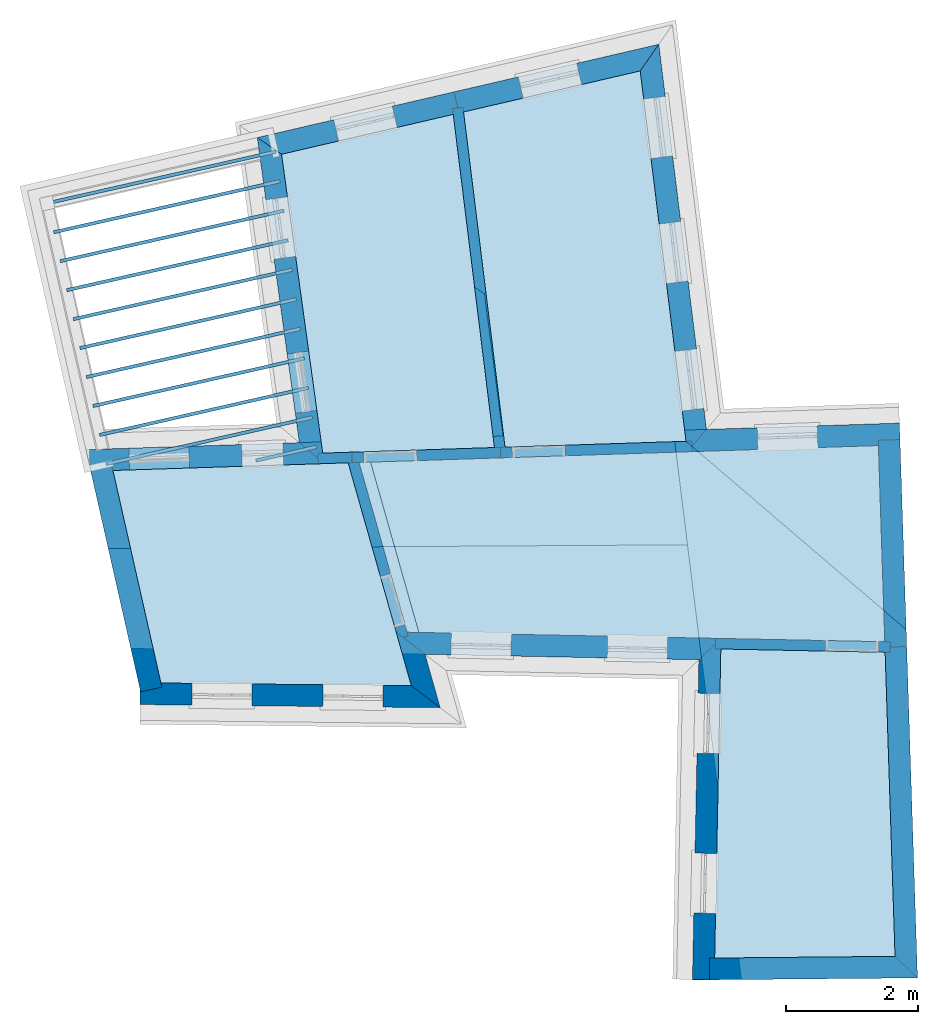
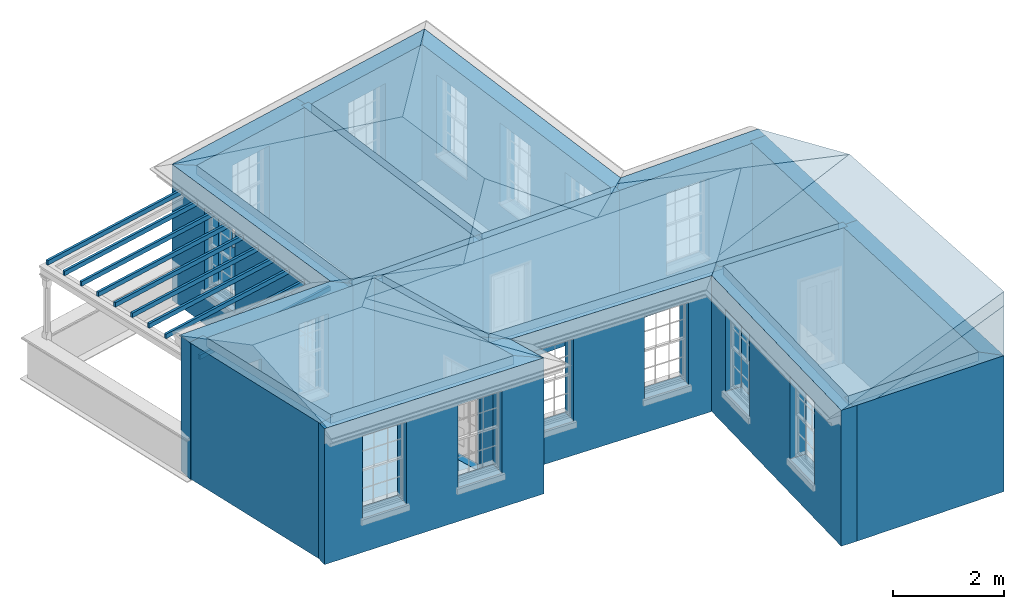
# One storey, part 1 of 11: 20 slabs, 20 walls, 5 roofs, 20 openings.
"""IFC2X3 building model written with IfcOpenShell, lengths in metres."""

import ifcopenshell
import ifcopenshell.guid

model = None  # the IFC model being written
_history = None  # IfcOwnerHistory: only IFC2X3 demands one
_inside = {}  # id of a spatial element -> (the spatial element, [elements in it])
_under = {}  # id of a project, library or spatial element -> (it, [spatial elements below it])
_declared = {}  # id of a project -> (the project, [libraries it declares])
_typed = {}  # id of a type object -> (the type object, [elements of that type])
_made_of = {}  # id of a material, layer set ... -> (it, [elements and type objects made of it])


def new_model(schema):
    """Start an empty IFC model of exactly this schema.

    Asked for "IFC4X3", IfcOpenShell would pick the latest addendum, in which some entities
    have other attributes; the version numbers below select the first issue.
    IFC2X3 requires an IfcOwnerHistory on every rooted entity: one is made here for all.
    """
    global model, _history
    if schema == "IFC4X3":
        model = ifcopenshell.file(schema_version=(4, 3, 0, 0))
    else:
        model = ifcopenshell.file(schema=schema)
    _inside.clear()
    _under.clear()
    _declared.clear()
    _typed.clear()
    _made_of.clear()
    _history = None
    if model.schema == "IFC2X3":
        org = make("IfcOrganization", Name="unknown")
        user = make(
            "IfcPersonAndOrganization",
            ThePerson=make("IfcPerson", FamilyName="unknown"),
            TheOrganization=org,
        )
        app = make(
            "IfcApplication",
            ApplicationDeveloper=org,
            Version="unknown",
            ApplicationFullName="unknown",
            ApplicationIdentifier="unknown",
        )
        _history = make(
            "IfcOwnerHistory",
            OwningUser=user,
            OwningApplication=app,
            ChangeAction="ADDED",
            CreationDate=0,
        )
    return model


def make(cls, **values):
    """One entity of the class cls with the attributes given. An attribute that is None is left unset."""
    return model.create_entity(
        cls, **{name: value for name, value in values.items() if value is not None}
    )


def rooted(cls, **values):
    """An entity with a GlobalId (a new one), such as an element, a storey or a relation."""
    return make(cls, GlobalId=ifcopenshell.guid.new(), OwnerHistory=_history, **values)


def si_unit(unit_type, name, prefix=None):
    """IfcSIUnit, for example si_unit("LENGTHUNIT", "METRE", prefix="MILLI")."""
    return make("IfcSIUnit", UnitType=unit_type, Prefix=prefix, Name=name)


def assignment(units):
    """IfcUnitAssignment: the units of a project."""
    return None if units is None else make("IfcUnitAssignment", Units=units)


def point(xyz):
    """IfcCartesianPoint."""
    return None if xyz is None else make("IfcCartesianPoint", Coordinates=xyz)


def direction(xyz):
    """IfcDirection."""
    return None if xyz is None else make("IfcDirection", DirectionRatios=xyz)


def frame(location, z_axis=None, x_axis=None):
    """IfcAxis2Placement3D, a coordinate frame: its origin and axes. An axis left out is left unset."""
    return make(
        "IfcAxis2Placement3D",
        Location=point(location),
        Axis=direction(z_axis),
        RefDirection=direction(x_axis),
    )


def origin():
    """The frame at (0, 0, 0) with its axes left unset."""
    return frame((0.0, 0.0, 0.0))


def place(relative_to, where):
    """IfcLocalPlacement: puts the frame where relative to a parent placement (None: the world)."""
    return make(
        "IfcLocalPlacement", PlacementRelTo=relative_to, RelativePlacement=where
    )


def context(
    kind, dimensions, precision=None, world=None, true_north=None, identifier=None
):
    """IfcGeometricRepresentationContext, for example the 3D "Model" context."""
    return make(
        "IfcGeometricRepresentationContext",
        ContextIdentifier=identifier,
        ContextType=kind,
        CoordinateSpaceDimension=dimensions,
        Precision=precision,
        WorldCoordinateSystem=world,
        TrueNorth=true_north,
    )


def subcontext(parent, identifier, kind, view, scale=None):
    """IfcGeometricRepresentationSubContext, for example "Body" below "Model"."""
    return make(
        "IfcGeometricRepresentationSubContext",
        ContextIdentifier=identifier,
        ContextType=kind,
        ParentContext=parent,
        TargetScale=scale,
        TargetView=view,
    )


def project(units=None, contexts=None):
    """IfcProject with its units and contexts."""
    return rooted(
        "IfcProject",
        Name="project",
        RepresentationContexts=contexts,
        UnitsInContext=assignment(units),
    )


def spatial(cls, under=None, at=None, **own):
    """A site, building, storey or space (cls), placed at a placement, below another one or the project."""
    s = rooted(cls, ObjectPlacement=at, **own)
    if under is not None:
        _under.setdefault(under.id(), (under, []))[1].append(s)
    return s


def polyline(points):
    """IfcPolyline through the points."""
    return make("IfcPolyline", Points=[point(p) for p in points])


def outline(outer, holes=None, kind="AREA"):
    """IfcArbitraryClosedProfileDef: a profile drawn as a closed curve; with holes, ...WithVoids."""
    if holes is None:
        return make("IfcArbitraryClosedProfileDef", ProfileType=kind, OuterCurve=outer)
    return make(
        "IfcArbitraryProfileDefWithVoids",
        ProfileType=kind,
        OuterCurve=outer,
        InnerCurves=holes,
    )


def extrude(swept, where, along, depth):
    """IfcExtrudedAreaSolid: the profile swept, set in the frame where, extruded along a direction by depth."""
    return make(
        "IfcExtrudedAreaSolid",
        SweptArea=swept,
        Position=where,
        ExtrudedDirection=direction(along),
        Depth=depth,
    )


def faces_of(points, faces, orient=None, outer=None):
    """IfcFace entities. A face is a list of loops; a loop is a list of indices into points, from 0.

    orient and outer hold one flag for each loop. By default every Orientation is true, the
    first loop of a face is its IfcFaceOuterBound and the others are IfcFaceBound.
    """
    made = []
    for i, loops in enumerate(faces):
        bounds = []
        for j, loop in enumerate(loops):
            is_outer = j == 0 if outer is None else outer[i][j]
            bounds.append(
                make(
                    "IfcFaceOuterBound" if is_outer else "IfcFaceBound",
                    Bound=make("IfcPolyLoop", Polygon=[points[k] for k in loop]),
                    Orientation=True if orient is None else orient[i][j],
                )
            )
        made.append(make("IfcFace", Bounds=bounds))
    return made


def faceted_brep(points, faces, orient=None, outer=None, voids=None):
    """IfcFacetedBrep: a solid bounded by flat faces; with voids (closed shells), ...WithVoids."""
    shared = [point(p) for p in points]
    hull = make("IfcClosedShell", CfsFaces=faces_of(shared, faces, orient, outer))
    if voids is None:
        return make("IfcFacetedBrep", Outer=hull)
    return make(
        "IfcFacetedBrepWithVoids",
        Outer=hull,
        Voids=[
            make(cls, CfsFaces=faces_of(shared, fs, o, b)) for cls, fs, o, b in voids
        ],
    )


def shape(context_of_items, identifier, shape_type, items):
    """IfcShapeRepresentation: the items that make up one representation, for example the "Body"."""
    return make(
        "IfcShapeRepresentation",
        ContextOfItems=context_of_items,
        RepresentationIdentifier=identifier,
        RepresentationType=shape_type,
        Items=items,
    )


def material(Name=None, Category=None):
    """IfcMaterial."""
    return make("IfcMaterial", Name=Name, Category=Category)


def layer(
    of_material, thickness, ventilated=None, Name=None, Category=None, Priority=None
):
    """IfcMaterialLayer: one layer of a wall or slab, of a material (None: an air gap)."""
    return make(
        "IfcMaterialLayer",
        Material=of_material,
        LayerThickness=thickness,
        IsVentilated=ventilated,
        Name=Name,
        Category=Category,
        Priority=Priority,
    )


def layer_set(layers, Name=None):
    """IfcMaterialLayerSet."""
    return make("IfcMaterialLayerSet", MaterialLayers=layers, LayerSetName=Name)


def layer_usage(for_layer_set, set_direction, sense, offset, extent=None):
    """IfcMaterialLayerSetUsage: how a layer set lies in its element."""
    return make(
        "IfcMaterialLayerSetUsage",
        ForLayerSet=for_layer_set,
        LayerSetDirection=set_direction,
        DirectionSense=sense,
        OffsetFromReferenceLine=offset,
        ReferenceExtent=extent,
    )


def made_of(thing, what):
    """Note that an element or type object is made of a material, layer set ...; save() writes the relation."""
    if what is not None:
        _made_of.setdefault(what.id(), (what, []))[1].append(thing)
    return thing


def element(
    cls,
    number,
    at=None,
    inside=None,
    cuts=None,
    type_object=None,
    material=None,
    context=None,
    identifier="Body",
    shape_type=None,
    held_by="IfcProductDefinitionShape",
    body=None,
    shapes=None,
    **own,
):
    """One element of the class cls, such as IfcWall. Its Tag is "e" and its number.

    at: its placement. inside: the storey or other place that contains it. cuts: it is an
    opening in that element (IfcRelVoidsElement). A single representation is given by context,
    identifier, shape_type and body (its items); several are given by shapes. held_by: the class
    of the entity that holds the representations. save() writes the other relations.
    """
    e = rooted(cls, Tag="e%d" % number, ObjectPlacement=at, **own)
    if body is not None:
        shapes = [shape(context, identifier, shape_type, body)]
    if shapes is not None:
        e.Representation = make(held_by, Representations=shapes)
    if inside is not None:
        _inside.setdefault(inside.id(), (inside, []))[1].append(e)
    if cuts is not None:
        rooted(
            "IfcRelVoidsElement", RelatingBuildingElement=cuts, RelatedOpeningElement=e
        )
    if type_object is not None:
        _typed.setdefault(type_object.id(), (type_object, []))[1].append(e)
    return made_of(e, material)


def aggregate(whole, parts):
    """IfcRelAggregates: a whole, such as a stair, and the parts it consists of."""
    return rooted("IfcRelAggregates", RelatingObject=whole, RelatedObjects=parts)


def save(model, path):
    """Write the relations noted so far, then the file.

    IfcRelAggregates (storeys below a building ...), IfcRelContainedInSpatialStructure (elements
    in a storey), IfcRelDefinesByType, IfcRelAssociatesMaterial and IfcRelDeclares: one each for
    every whole, place, type object, material and project.
    """
    for whole, parts in _under.values():
        aggregate(whole, parts)
    for where, things in _inside.values():
        rooted(
            "IfcRelContainedInSpatialStructure",
            RelatedElements=things,
            RelatingStructure=where,
        )
    for kind, things in _typed.values():
        rooted("IfcRelDefinesByType", RelatedObjects=things, RelatingType=kind)
    for what, things in _made_of.values():
        rooted("IfcRelAssociatesMaterial", RelatedObjects=things, RelatingMaterial=what)
    for by, libraries in _declared.values():
        rooted("IfcRelDeclares", RelatingContext=by, RelatedDefinitions=libraries)
    model.write(path)


model = new_model("IFC2X3")

# Units and contexts
model_context = context("Model", 3, world=origin())
body_context = subcontext(model_context, "Body", "Model", "MODEL_VIEW")
ifc_project = project(units=[si_unit("PLANEANGLEUNIT", "RADIAN"), si_unit("MASSUNIT", "GRAM", prefix="KILO"), si_unit("FORCEUNIT", "NEWTON", prefix="KILO"), si_unit("LENGTHUNIT", "METRE")], contexts=[model_context])

# Site, building, storey
site_placement = place(None, origin())
site = spatial("IfcSite", under=ifc_project, at=site_placement, CompositionType="ELEMENT")
building_placement = place(None, origin())
building = spatial("IfcBuilding", under=site, at=building_placement, Name="Building plot-10", CompositionType="ELEMENT")
storey_placement = place(None, frame((0.0, 0.0, 4.6)))
storey = spatial("IfcBuildingStorey", under=building, at=storey_placement, Name="Floor 1", CompositionType="ELEMENT", Elevation=4.6)

# Slabs
slab_1_placement = place(storey_placement, frame((0.0, 0.0, 2.8)))
element("IfcSlab", 1, at=slab_1_placement, inside=storey, Name="Slab", ObjectType="Slab", PredefinedType="FLOOR", context=body_context, shape_type="SweptSolid", body=[
    extrude(outline(polyline([(44.9687623630564, 20.0644223525084), (47.571080180926, 20.1492024346125), (46.9465776852697, 25.1981692437255), (44.3445319443295, 24.5935944613253), (44.9687623630564, 20.0644223525084)])), origin(), (0.0, 0.0, 1.0), 0.2),
])
slab_2_placement = place(storey_placement, frame((0.0, 0.0, 2.8)))
element("IfcSlab", 2, at=slab_2_placement, inside=storey, Name="Slab", ObjectType="Slab", PredefinedType="FLOOR", context=body_context, shape_type="SweptSolid", body=[
    extrude(outline(polyline([(47.7316524093399, 20.1544336660228), (50.4741271537096, 20.2437798759283), (49.7798970152204, 25.8564795072323), (47.1032931648619, 25.2345814502761), (47.7316524093399, 20.1544336660228)])), origin(), (0.0, 0.0, 1.0), 0.2),
])
slab_3_placement = place(storey_placement, frame((0.0, 0.0, 2.8)))
element("IfcSlab", 3, at=slab_3_placement, inside=storey, Name="Slab", ObjectType="Slab", PredefinedType="FLOOR", context=body_context, shape_type="SweptSolid", body=[
    extrude(outline(polyline([(50.9088867072119, 12.4121083664368), (53.6421689030636, 12.4374095923594), (53.492033323382, 17.0458091645808), (51.0022137485396, 17.0954251747444), (50.9088867072119, 12.4121083664368)])), origin(), (0.0, 0.0, 1.0), 0.2),
])
slab_4_placement = place(storey_placement, frame((0.0, 0.0, 2.8)))
element("IfcSlab", 4, at=slab_4_placement, inside=storey, Name="Slab", ObjectType="Slab", PredefinedType="FLOOR", context=body_context, shape_type="SweptSolid", body=[
    extrude(outline(polyline([(53.4868163125895, 17.2059448922715), (53.3899682225677, 20.1786892449006), (45.518706952501, 19.9222539347489), (46.2478796896365, 17.3501991814926), (53.4868163125895, 17.2059448922715)])), origin(), (0.0, 0.0, 1.0), 0.2),
])
slab_5_placement = place(storey_placement, frame((0.0, 0.0, 2.5)))
element("IfcSlab", 5, at=slab_5_placement, inside=storey, Name="Slab", ObjectType="Slab", PredefinedType="FLOOR", context=body_context, shape_type="SweptSolid", body=[
    extrude(outline(polyline([(40.7869713452869, 23.8748061275973), (40.7979865889235, 23.8260345743349), (44.2638256075532, 24.6088077000976), (44.2528103639166, 24.65757925336), (40.7869713452869, 23.8748061275973)])), origin(), (0.0, 0.0, 1.0), 0.1),
])
slab_6_placement = place(storey_placement, frame((0.0, 0.0, 2.5)))
element("IfcSlab", 6, at=slab_6_placement, inside=storey, Name="Slab", ObjectType="Slab", PredefinedType="FLOOR", context=body_context, shape_type="SweptSolid", body=[
    extrude(outline(polyline([(40.8861085380164, 23.4358621482358), (40.8971237816531, 23.3870905949734), (44.3254892794257, 24.1614001813458), (44.314474035789, 24.2101717346082), (40.8861085380164, 23.4358621482358)])), origin(), (0.0, 0.0, 1.0), 0.1),
])
slab_7_placement = place(storey_placement, frame((0.0, 0.0, 2.5)))
element("IfcSlab", 7, at=slab_7_placement, inside=storey, Name="Slab", ObjectType="Slab", PredefinedType="FLOOR", context=body_context, shape_type="SweptSolid", body=[
    extrude(outline(polyline([(40.985245730746, 22.9969181688743), (40.9962609743826, 22.9481466156119), (44.3871529512981, 23.713992662594), (44.3761377076615, 23.7627642158564), (40.985245730746, 22.9969181688743)])), origin(), (0.0, 0.0, 1.0), 0.1),
])
slab_8_placement = place(storey_placement, frame((0.0, 0.0, 2.5)))
element("IfcSlab", 8, at=slab_8_placement, inside=storey, Name="Slab", ObjectType="Slab", PredefinedType="FLOOR", context=body_context, shape_type="SweptSolid", body=[
    extrude(outline(polyline([(41.0843829234756, 22.5579741895128), (41.0953981671122, 22.5092026362504), (44.4488166231706, 23.2665851438422), (44.437801379534, 23.3153566971046), (41.0843829234756, 22.5579741895128)])), origin(), (0.0, 0.0, 1.0), 0.1),
])
slab_9_placement = place(storey_placement, frame((0.0, 0.0, 2.5)))
element("IfcSlab", 9, at=slab_9_placement, inside=storey, Name="Slab", ObjectType="Slab", PredefinedType="FLOOR", context=body_context, shape_type="SweptSolid", body=[
    extrude(outline(polyline([(41.1835201162051, 22.1190302101513), (41.1945353598417, 22.0702586568889), (44.510480295043, 22.8191776250904), (44.4994650514064, 22.8679491783528), (41.1835201162051, 22.1190302101513)])), origin(), (0.0, 0.0, 1.0), 0.1),
])
slab_10_placement = place(storey_placement, frame((0.0, 0.0, 2.5)))
element("IfcSlab", 10, at=slab_10_placement, inside=storey, Name="Slab", ObjectType="Slab", PredefinedType="FLOOR", context=body_context, shape_type="SweptSolid", body=[
    extrude(outline(polyline([(41.2826573089347, 21.6800862307898), (41.2936725525713, 21.6313146775274), (44.5721439669155, 22.3717701063386), (44.5611287232789, 22.420541659601), (41.2826573089347, 21.6800862307898)])), origin(), (0.0, 0.0, 1.0), 0.1),
])
slab_11_placement = place(storey_placement, frame((0.0, 0.0, 2.5)))
element("IfcSlab", 11, at=slab_11_placement, inside=storey, Name="Slab", ObjectType="Slab", PredefinedType="FLOOR", context=body_context, shape_type="SweptSolid", body=[
    extrude(outline(polyline([(41.3817945016642, 21.2411422514283), (41.3928097453009, 21.1923706981659), (44.6338076387879, 21.9243625875868), (44.6227923951513, 21.9731341408492), (41.3817945016642, 21.2411422514283)])), origin(), (0.0, 0.0, 1.0), 0.1),
])
slab_12_placement = place(storey_placement, frame((0.0, 0.0, 2.5)))
element("IfcSlab", 12, at=slab_12_placement, inside=storey, Name="Slab", ObjectType="Slab", PredefinedType="FLOOR", context=body_context, shape_type="SweptSolid", body=[
    extrude(outline(polyline([(41.4809316943938, 20.8021982720668), (41.4919469380304, 20.7534267188045), (44.6954713106604, 21.476955068835), (44.6844560670238, 21.5257266220974), (41.4809316943938, 20.8021982720668)])), origin(), (0.0, 0.0, 1.0), 0.1),
])
slab_13_placement = place(storey_placement, frame((0.0, 0.0, 2.5)))
element("IfcSlab", 13, at=slab_13_placement, inside=storey, Name="Slab", ObjectType="Slab", PredefinedType="FLOOR", context=body_context, shape_type="SweptSolid", body=[
    extrude(outline(polyline([(41.5800688871233, 20.3632542927054), (41.59108413076, 20.314482739443), (44.7571349825329, 21.0295475500832), (44.7461197388963, 21.0783191033456), (41.5800688871233, 20.3632542927054)])), origin(), (0.0, 0.0, 1.0), 0.1),
])
slab_14_placement = place(storey_placement, frame((0.0, 0.0, 2.5)))
element("IfcSlab", 14, at=slab_14_placement, inside=storey, Name="Slab", ObjectType="Slab", PredefinedType="FLOOR", context=body_context, shape_type="SweptSolid", body=[
    extrude(outline(polyline([(41.6792060798529, 19.9243103133439), (41.6902213234895, 19.8755387600815), (44.8187986544053, 20.5821400313314), (44.8077834107687, 20.6309115845938), (41.6792060798529, 19.9243103133439)])), origin(), (0.0, 0.0, 1.0), 0.1),
])
slab_15_placement = place(storey_placement, frame((0.0, 0.0, 2.5)))
element("IfcSlab", 15, at=slab_15_placement, inside=storey, Name="Slab", ObjectType="Slab", PredefinedType="FLOOR", context=body_context, shape_type="SweptSolid", body=[
    extrude(outline(polyline([(43.9495436082797, 19.9757403139322), (43.9605588519164, 19.9269687606698), (44.8804623262778, 20.1347325125796), (44.8694470826412, 20.183504065842), (43.9495436082797, 19.9757403139322)])), origin(), (0.0, 0.0, 1.0), 0.1),
])
slab_16_placement = place(storey_placement, frame((0.0, 0.0, 2.8)))
element("IfcSlab", 16, at=slab_16_placement, inside=storey, Name="Slab", ObjectType="Slab", PredefinedType="FLOOR", context=body_context, shape_type="SweptSolid", body=[
    extrude(outline(polyline([(46.3113508516478, 16.5396943502031), (45.3539234425677, 19.9168855053412), (41.7891278635455, 19.8007491672666), (42.5166255010049, 16.5796502116643), (46.3113508516478, 16.5396943502031)])), origin(), (0.0, 0.0, 1.0), 0.2),
])
slab_17_placement = place(storey_placement, origin())
element("IfcSlab", 17, at=slab_17_placement, inside=storey, Name="Slab", ObjectType="Slab", PredefinedType="FLOOR", context=body_context, shape_type="SweptSolid", body=[
    extrude(outline(polyline([(44.9687623630564, 20.0644223525084), (47.571080180926, 20.1492024346125), (46.9465776852697, 25.1981692437255), (44.3445319443295, 24.5935944613253), (44.9687623630564, 20.0644223525084)])), origin(), (0.0, 0.0, 1.0), 0.02),
])
slab_18_placement = place(storey_placement, origin())
element("IfcSlab", 18, at=slab_18_placement, inside=storey, Name="Slab", ObjectType="Slab", PredefinedType="FLOOR", context=body_context, shape_type="SweptSolid", body=[
    extrude(outline(polyline([(47.7316524093399, 20.1544336660228), (50.4741271537096, 20.2437798759283), (49.7798970152204, 25.8564795072323), (47.1032931648619, 25.2345814502761), (47.7316524093399, 20.1544336660228)])), origin(), (0.0, 0.0, 1.0), 0.02),
])
slab_19_placement = place(storey_placement, origin())
element("IfcSlab", 19, at=slab_19_placement, inside=storey, Name="Slab", ObjectType="Slab", PredefinedType="FLOOR", context=body_context, shape_type="SweptSolid", body=[
    extrude(outline(polyline([(50.9088867072119, 12.4121083664368), (53.6421689030636, 12.4374095923594), (53.492033323382, 17.0458091645808), (51.0022137485396, 17.0954251747444), (50.9088867072119, 12.4121083664368)])), origin(), (0.0, 0.0, 1.0), 0.02),
])
slab_20_placement = place(storey_placement, origin())
element("IfcSlab", 20, at=slab_20_placement, inside=storey, Name="Slab", ObjectType="Slab", PredefinedType="FLOOR", context=body_context, shape_type="SweptSolid", body=[
    extrude(outline(polyline([(46.3113508516478, 16.5396943502031), (45.3539234425677, 19.9168855053412), (41.7891278635455, 19.8007491672666), (42.5166255010049, 16.5796502116643), (46.3113508516478, 16.5396943502031)])), origin(), (0.0, 0.0, 1.0), 0.02),
])

# Wall, openings
ifc_material_1 = material(Name="Masonry")
ifc_layer_1 = layer(ifc_material_1, 0.33, ventilated=False)
ifc_layer_set_1 = layer_set([ifc_layer_1], Name="My Wall")
ifc_layer_usage_1 = layer_usage(ifc_layer_set_1, "AXIS2", "NEGATIVE", 0.08)
wall_1_placement = place(storey_placement, origin())
wall_1 = element("IfcWallStandardCase", 21, at=wall_1_placement, inside=storey, material=ifc_layer_usage_1, Name="exterior", context=body_context, shape_type="SweptSolid", body=[
    extrude(outline(polyline([(42.2033835145621, 16.5829484354506), (42.1999090329559, 16.2529667269006), (46.749222478465, 16.2050655691155), (46.3113508516478, 16.5396943502031), (42.2033835145621, 16.5829484354506)])), origin(), (0.0, 0.0, 1.0), 3.0),
])
opening_1_placement = place(storey_placement, frame((0.0, 0.0, 0.75)))
element("IfcOpeningElement", 22, at=opening_1_placement, cuts=wall_1, Name="Opening", ObjectType="Opening", context=body_context, shape_type="SweptSolid", body=[
    extrude(outline(polyline([(42.9861639433829, 16.2446880006764), (43.8961135033238, 16.2351068544289), (43.89958798493, 16.5650885629789), (42.9896384249891, 16.5746697092264), (42.9861639433829, 16.2446880006764)])), origin(), (0.0, 0.0, 1.0), 1.82),
])
opening_2_placement = place(storey_placement, frame((0.0, 0.0, 0.75)))
element("IfcOpeningElement", 23, at=opening_2_placement, cuts=wall_1, Name="Opening", ObjectType="Opening", context=body_context, shape_type="SweptSolid", body=[
    extrude(outline(polyline([(44.968651038496, 16.2238137680504), (45.8786005984369, 16.2142326218029), (45.8820750800431, 16.5442143303529), (44.9721255201022, 16.5537954766004), (44.968651038496, 16.2238137680504)])), origin(), (0.0, 0.0, 1.0), 1.82),
])

# Wall
wall_2_placement = place(storey_placement, origin())
element("IfcWallStandardCase", 24, at=wall_2_placement, inside=storey, material=ifc_layer_usage_1, Name="exterior", context=body_context, shape_type="SweptSolid", body=[
    extrude(outline(polyline([(46.3113508516478, 16.5396943502031), (46.749222478465, 16.2050655691155), (46.5196877486523, 17.0147171959322), (46.0806293719887, 17.3535320709695), (46.3113508516478, 16.5396943502031)])), origin(), (0.0, 0.0, 1.0), 3.0),
])

# Wall, openings
wall_3_placement = place(storey_placement, origin())
wall_3 = element("IfcWallStandardCase", 25, at=wall_3_placement, inside=storey, material=ifc_layer_usage_1, Name="exterior", context=body_context, shape_type="SweptSolid", body=[
    extrude(outline(polyline([(46.0806293719887, 17.3535320709695), (46.5196877486523, 17.0147171959322), (50.6688922402643, 16.9320337058085), (51.0054015240496, 17.2553934156152), (46.0806293719887, 17.3535320709695)])), origin(), (0.0, 0.0, 1.0), 3.0),
])
opening_3_placement = place(storey_placement, frame((0.0, 0.0, 0.75)))
element("IfcOpeningElement", 26, at=opening_3_placement, cuts=wall_3, Name="Opening", ObjectType="Opening", context=body_context, shape_type="SweptSolid", body=[
    extrude(outline(polyline([(46.9113661195027, 17.0069120046544), (47.8211854894554, 16.9887815314415), (47.8277602764447, 17.3187160282375), (46.917940906492, 17.3368465014504), (46.9113661195027, 17.0069120046544)])), origin(), (0.0, 0.0, 1.0), 1.82),
])
opening_4_placement = place(storey_placement, frame((0.0, 0.0, 0.75)))
element("IfcOpeningElement", 27, at=opening_4_placement, cuts=wall_3, Name="Opening", ObjectType="Opening", context=body_context, shape_type="SweptSolid", body=[
    extrude(outline(polyline([(49.2797439942666, 16.9597160303385), (50.1895633642193, 16.9415855571257), (50.1961381512086, 17.2715200539217), (49.2863187812559, 17.2896505271346), (49.2797439942666, 16.9597160303385)])), origin(), (0.0, 0.0, 1.0), 1.82),
])

wall_4_placement = place(storey_placement, origin())
wall_4 = element("IfcWallStandardCase", 28, at=wall_4_placement, inside=storey, material=ifc_layer_usage_1, Name="exterior", context=body_context, shape_type="SweptSolid", body=[
    extrude(outline(polyline([(51.0054015240496, 17.2553934156152), (50.6688922402643, 16.9320337058085), (50.5723302195108, 12.0863798802376), (50.9022647163068, 12.0798050932483), (51.0054015240496, 17.2553934156152)])), origin(), (0.0, 0.0, 1.0), 3.0),
])
opening_5_placement = place(storey_placement, frame((0.0, 0.0, 0.75)))
element("IfcOpeningElement", 29, at=opening_5_placement, cuts=wall_4, Name="Opening", ObjectType="Opening", context=body_context, shape_type="SweptSolid", body=[
    extrude(outline(polyline([(50.6587978709166, 16.4254803107527), (50.6406673977038, 15.5156609408), (50.9706018944998, 15.5090861538108), (50.9887323677127, 16.4189055237634), (50.6587978709166, 16.4254803107527)])), origin(), (0.0, 0.0, 1.0), 1.82),
])
opening_6_placement = place(storey_placement, frame((0.0, 0.0, 0.75)))
element("IfcOpeningElement", 30, at=opening_6_placement, cuts=wall_4, Name="Opening", ObjectType="Opening", context=body_context, shape_type="SweptSolid", body=[
    extrude(outline(polyline([(50.6105168605399, 14.0026533979673), (50.592386387327, 13.0928340280146), (50.922320884123, 13.0862592410253), (50.9404513573359, 13.996078610978), (50.6105168605399, 14.0026533979673)])), origin(), (0.0, 0.0, 1.0), 1.82),
])

# Wall, opening
wall_5_placement = place(storey_placement, origin())
wall_5 = element("IfcWallStandardCase", 31, at=wall_5_placement, inside=storey, material=ifc_layer_usage_1, Name="exterior", context=body_context, shape_type="SweptSolid", body=[
    extrude(outline(polyline([(53.7197932357243, 20.1894345087971), (53.7090479718279, 20.5192595219538), (50.7843534970595, 20.4239768335759), (50.4938484504191, 20.0843374826447), (53.7197932357243, 20.1894345087971)])), origin(), (0.0, 0.0, 1.0), 3.0),
])
opening_7_placement = place(storey_placement, frame((0.0, 0.0, 0.75)))
element("IfcOpeningElement", 32, at=opening_7_placement, cuts=wall_5, Name="Opening", ObjectType="Opening", context=body_context, shape_type="SweptSolid", body=[
    extrude(outline(polyline([(52.4624157814879, 20.478645889474), (51.552898320965, 20.4490150102444), (51.5636435848614, 20.1191899970877), (52.4731610453844, 20.1488208763173), (52.4624157814879, 20.478645889474)])), origin(), (0.0, 0.0, 1.0), 1.82),
])

# Wall, openings
wall_6_placement = place(storey_placement, origin())
wall_6 = element("IfcWallStandardCase", 33, at=wall_6_placement, inside=storey, material=ifc_layer_usage_1, Name="exterior", context=body_context, shape_type="SweptSolid", body=[
    extrude(outline(polyline([(50.4938484504191, 20.0843374826447), (50.7843534970595, 20.4239768335759), (50.0623886340856, 26.2609056783057), (49.7798970152204, 25.8564795072323), (50.4938484504191, 20.0843374826447)])), origin(), (0.0, 0.0, 1.0), 3.0),
])
opening_8_placement = place(storey_placement, frame((0.0, 0.0, 0.75)))
element("IfcOpeningElement", 34, at=opening_8_placement, cuts=wall_6, Name="Opening", ObjectType="Opening", context=body_context, shape_type="SweptSolid", body=[
    extrude(outline(polyline([(50.7448686581057, 20.7432031661003), (50.6331627679987, 21.6463209846131), (50.3056585041424, 21.6058122552337), (50.4173643942494, 20.7026944367208), (50.7448686581057, 20.7432031661003)])), origin(), (0.0, 0.0, 1.0), 1.82),
])
opening_9_placement = place(storey_placement, frame((0.0, 0.0, 0.75)))
element("IfcOpeningElement", 35, at=opening_9_placement, cuts=wall_6, Name="Opening", ObjectType="Opening", context=body_context, shape_type="SweptSolid", body=[
    extrude(outline(polyline([(50.5062372966536, 22.6724858062268), (50.3945314065466, 23.5756036247397), (50.0670271426903, 23.5350948953602), (50.1787330327973, 22.6319770768474), (50.5062372966536, 22.6724858062268)])), origin(), (0.0, 0.0, 1.0), 1.82),
])
opening_10_placement = place(storey_placement, frame((0.0, 0.0, 0.75)))
element("IfcOpeningElement", 36, at=opening_10_placement, cuts=wall_6, Name="Opening", ObjectType="Opening", context=body_context, shape_type="SweptSolid", body=[
    extrude(outline(polyline([(50.2716577484948, 24.5690104173997), (50.1599518583878, 25.4721282359125), (49.8324475945315, 25.4316195065331), (49.9441534846385, 24.5285016880202), (50.2716577484948, 24.5690104173997)])), origin(), (0.0, 0.0, 1.0), 1.82),
])

# Wall, opening
wall_7_placement = place(storey_placement, origin())
wall_7 = element("IfcWallStandardCase", 37, at=wall_7_placement, inside=storey, material=ifc_layer_usage_1, Name="exterior", context=body_context, shape_type="SweptSolid", body=[
    extrude(outline(polyline([(49.7798970152204, 25.8564795072323), (50.0623886340856, 26.2609056783057), (46.9584811499292, 25.5397253538022), (47.0331658946155, 25.2182876632444), (49.7798970152204, 25.8564795072323)])), origin(), (0.0, 0.0, 1.0), 3.0),
])
opening_11_placement = place(storey_placement, frame((0.0, 0.0, 0.75)))
element("IfcOpeningElement", 38, at=opening_11_placement, cuts=wall_7, Name="Opening", ObjectType="Opening", context=body_context, shape_type="SweptSolid", body=[
    extrude(outline(polyline([(48.8183352064313, 25.9718549062595), (47.9319464233779, 25.7659060648518), (48.0066311680642, 25.444468374294), (48.8930199511176, 25.6504172157017), (48.8183352064313, 25.9718549062595)])), origin(), (0.0, 0.0, 1.0), 1.82),
])

wall_8_placement = place(storey_placement, origin())
wall_8 = element("IfcWallStandardCase", 39, at=wall_8_placement, inside=storey, material=ifc_layer_usage_1, Name="exterior", context=body_context, shape_type="SweptSolid", body=[
    extrude(outline(polyline([(47.0331658946155, 25.2182876632444), (46.9584811499292, 25.5397253538022), (43.9765041708865, 24.846875088005), (44.3445319443295, 24.5935944613253), (47.0331658946155, 25.2182876632444)])), origin(), (0.0, 0.0, 1.0), 3.0),
])
opening_12_placement = place(storey_placement, frame((0.0, 0.0, 0.75)))
element("IfcOpeningElement", 40, at=opening_12_placement, cuts=wall_8, Name="Opening", ObjectType="Opening", context=body_context, shape_type="SweptSolid", body=[
    extrude(outline(polyline([(46.0218018355545, 25.3220917112583), (45.1354130525011, 25.1161428698506), (45.2100977971874, 24.7947051792928), (46.0964865802408, 25.0006540207005), (46.0218018355545, 25.3220917112583)])), origin(), (0.0, 0.0, 1.0), 1.82),
])

# Wall, openings
wall_9_placement = place(storey_placement, origin())
wall_9 = element("IfcWallStandardCase", 41, at=wall_9_placement, inside=storey, material=ifc_layer_usage_1, Name="exterior", context=body_context, shape_type="SweptSolid", body=[
    extrude(outline(polyline([(44.3445319443295, 24.5935944613253), (43.9765041708865, 24.846875088005), (44.613794117192, 20.222948147817), (44.9907273404709, 19.9050530553829), (44.3445319443295, 24.5935944613253)])), origin(), (0.0, 0.0, 1.0), 3.0),
])
opening_13_placement = place(storey_placement, frame((0.0, 0.0, 0.75)))
element("IfcOpeningElement", 42, at=opening_13_placement, cuts=wall_9, Name="Opening", ObjectType="Opening", context=body_context, shape_type="SweptSolid", body=[
    extrude(outline(polyline([(44.1065405118972, 23.9033821867153), (44.2307862067584, 23.001903952198), (44.5576958961987, 23.0469600833015), (44.4334502013375, 23.9484383178188), (44.1065405118972, 23.9033821867153)])), origin(), (0.0, 0.0, 1.0), 1.82),
])
opening_14_placement = place(storey_placement, frame((0.0, 0.0, 0.0199999999999996)))
element("IfcOpeningElement", 43, at=opening_14_placement, cuts=wall_9, Name="Opening", ObjectType="Opening", context=body_context, shape_type="SweptSolid", body=[
    extrude(outline(polyline([(44.4285587615029, 21.5669435401992), (44.5528044563641, 20.6654653056818), (44.8797141458044, 20.7105214367853), (44.7554684509432, 21.6119996713027), (44.4285587615029, 21.5669435401992)])), origin(), (0.0, 0.0, 1.0), 2.08),
])

wall_10_placement = place(storey_placement, origin())
wall_10 = element("IfcWallStandardCase", 44, at=wall_10_placement, inside=storey, material=ifc_layer_usage_1, Name="exterior", context=body_context, shape_type="SweptSolid", body=[
    extrude(outline(polyline([(44.9907273404709, 19.9050530553829), (44.613794117192, 20.222948147817), (41.4317582674974, 20.1192816168719), (41.4425035313938, 19.7894566037152), (44.9907273404709, 19.9050530553829)])), origin(), (0.0, 0.0, 1.0), 3.0),
])
opening_15_placement = place(storey_placement, frame((0.0, 0.0, 0.75)))
element("IfcOpeningElement", 45, at=opening_15_placement, cuts=wall_10, Name="Opening", ObjectType="Opening", context=body_context, shape_type="SweptSolid", body=[
    extrude(outline(polyline([(44.3630246910205, 20.2147784106719), (43.7383561054965, 20.1944275320802), (43.7491013693929, 19.8646025189235), (44.3737699549169, 19.8849533975153), (44.3630246910205, 20.2147784106719)])), origin(), (0.0, 0.0, 1.0), 1.82),
])
opening_16_placement = place(storey_placement, frame((0.0, 0.0, 0.0199999999999996)))
element("IfcOpeningElement", 46, at=opening_16_placement, cuts=wall_10, Name="Opening", ObjectType="Opening", context=body_context, shape_type="SweptSolid", body=[
    extrude(outline(polyline([(42.9387803160258, 20.1683784074828), (42.0292628555029, 20.1387475282532), (42.0400081193993, 19.8089225150966), (42.9495255799222, 19.8385533943261), (42.9387803160258, 20.1683784074828)])), origin(), (0.0, 0.0, 1.0), 2.08),
])

# Walls
wall_11_placement = place(storey_placement, origin())
element("IfcWallStandardCase", 47, at=wall_11_placement, inside=storey, material=ifc_layer_usage_1, Name="party", context=body_context, shape_type="SweptSolid", body=[
    extrude(outline(polyline([(50.8265209892907, 12.4113459301101), (50.8295755757776, 12.081360067532), (53.9829926252899, 12.1105503638428), (53.6421689030636, 12.4374095923594), (50.8265209892907, 12.4113459301101)])), origin(), (0.0, 0.0, 1.0), 3.0),
])
wall_12_placement = place(storey_placement, origin())
element("IfcWallStandardCase", 48, at=wall_12_placement, inside=storey, material=ifc_layer_usage_1, Name="party", context=body_context, shape_type="SweptSolid", body=[
    extrude(outline(polyline([(53.6421689030636, 12.4374095923594), (53.9829926252899, 12.1105503638428), (53.8193866941375, 17.1324212936703), (53.4895616809808, 17.1216760297739), (53.6421689030636, 12.4374095923594)])), origin(), (0.0, 0.0, 1.0), 3.0),
])
wall_13_placement = place(storey_placement, origin())
element("IfcWallStandardCase", 49, at=wall_13_placement, inside=storey, material=ifc_layer_usage_1, Name="party", context=body_context, shape_type="SweptSolid", body=[
    extrude(outline(polyline([(53.4895616809808, 17.1216760297739), (53.8193866941375, 17.1324212936703), (53.7171883232646, 20.2693920877442), (53.3873633101079, 20.2586468238478), (53.4895616809808, 17.1216760297739)])), origin(), (0.0, 0.0, 1.0), 3.0),
])
wall_14_placement = place(storey_placement, origin())
element("IfcWallStandardCase", 50, at=wall_14_placement, inside=storey, material=ifc_layer_usage_1, Name="party", context=body_context, shape_type="SweptSolid", body=[
    extrude(outline(polyline([(41.7678005383635, 19.8951789239176), (41.4459082868318, 19.8224783159159), (42.2086695925199, 16.4452444685234), (42.5305618440516, 16.5179450765251), (41.7678005383635, 19.8951789239176)])), origin(), (0.0, 0.0, 1.0), 3.0),
])
ifc_material_2 = material(Name="Masonry")
ifc_layer_2 = layer(ifc_material_2, 0.16, ventilated=False)
ifc_layer_set_2 = layer_set([ifc_layer_2], Name="My Wall")
ifc_layer_usage_2 = layer_usage(ifc_layer_set_2, "AXIS2", "NEGATIVE", 0.08)
wall_15_placement = place(storey_placement, origin())
element("IfcWallStandardCase", 51, at=wall_15_placement, inside=storey, material=ifc_layer_usage_2, Name="interior", context=body_context, shape_type="SweptSolid", body=[
    extrude(outline(polyline([(47.5818319704316, 20.0622765556445), (47.7406219165438, 20.0819171517073), (47.0944554750204, 25.3060322498959), (46.9356655289082, 25.2863916538331), (47.5818319704316, 20.0622765556445)])), origin(), (0.0, 0.0, 1.0), 3.0),
])
wall_16_placement = place(storey_placement, origin())
element("IfcWallStandardCase", 52, at=wall_16_placement, inside=storey, material=ifc_layer_usage_2, Name="interior", context=body_context, shape_type="SweptSolid", body=[
    extrude(outline(polyline([(44.8967446769133, 20.0620761112837), (44.9019545018327, 19.9021609533895), (45.416435890318, 19.9189220784363), (45.4112260653986, 20.0788372363305), (44.8967446769133, 20.0620761112837)])), origin(), (0.0, 0.0, 1.0), 3.0),
])

# Wall, opening
wall_17_placement = place(storey_placement, origin())
wall_17 = element("IfcWallStandardCase", 53, at=wall_17_placement, inside=storey, material=ifc_layer_usage_2, Name="interior", context=body_context, shape_type="SweptSolid", body=[
    extrude(outline(polyline([(47.658622031028, 20.152054432623), (47.6638318559474, 19.9921392747288), (50.566878828731, 20.0867167160446), (50.5616690038116, 20.2466318739388), (47.658622031028, 20.152054432623)])), origin(), (0.0, 0.0, 1.0), 3.0),
])
opening_17_placement = place(storey_placement, frame((0.0, 0.0, 0.0199999999999996)))
element("IfcOpeningElement", 54, at=opening_17_placement, cuts=wall_17, Name="Opening", ObjectType="Opening", context=body_context, shape_type="SweptSolid", body=[
    extrude(outline(polyline([(47.8437364085784, 19.9980003277633), (48.6433121980491, 20.0240494523607), (48.6381023731296, 20.1839646102548), (47.8385265836589, 20.1579154856574), (47.8437364085784, 19.9980003277633)])), origin(), (0.0, 0.0, 1.0), 2.1),
])

wall_18_placement = place(storey_placement, origin())
wall_18 = element("IfcWallStandardCase", 55, at=wall_18_placement, inside=storey, material=ifc_layer_usage_2, Name="interior", context=body_context, shape_type="SweptSolid", body=[
    extrude(outline(polyline([(45.4112260653986, 20.0788372363305), (45.416435890318, 19.9189220784363), (47.6638318559474, 19.9921392747288), (47.658622031028, 20.152054432623), (45.4112260653986, 20.0788372363305)])), origin(), (0.0, 0.0, 1.0), 3.0),
])
opening_18_placement = place(storey_placement, frame((0.0, 0.0, 0.0199999999999996)))
element("IfcOpeningElement", 56, at=opening_18_placement, cuts=wall_18, Name="Opening", ObjectType="Opening", context=body_context, shape_type="SweptSolid", body=[
    extrude(outline(polyline([(45.596340442949, 19.9247831314708), (46.3959162324197, 19.9508322560682), (46.3907064075002, 20.1107474139623), (45.5911306180295, 20.0846982893649), (45.596340442949, 19.9247831314708)])), origin(), (0.0, 0.0, 1.0), 2.1),
])

wall_19_placement = place(storey_placement, origin())
wall_19 = element("IfcWallStandardCase", 57, at=wall_19_placement, inside=storey, material=ifc_layer_usage_2, Name="interior", context=body_context, shape_type="SweptSolid", body=[
    extrude(outline(polyline([(53.5679253721729, 17.0442968217982), (53.5711131476829, 17.204265062669), (50.9254174036142, 17.2569873033702), (50.9222296281042, 17.0970190624994), (53.5679253721729, 17.0442968217982)])), origin(), (0.0, 0.0, 1.0), 3.0),
])
opening_19_placement = place(storey_placement, frame((0.0, 0.0, 0.0199999999999996)))
element("IfcOpeningElement", 58, at=opening_19_placement, cuts=wall_19, Name="Opening", ObjectType="Opening", context=body_context, shape_type="SweptSolid", body=[
    extrude(outline(polyline([(53.3911488767032, 17.2078513101177), (52.5913076723492, 17.2237901876675), (52.5881198968393, 17.0638219467967), (53.3879611011933, 17.0478830692469), (53.3911488767032, 17.2078513101177)])), origin(), (0.0, 0.0, 1.0), 2.1),
])

wall_20_placement = place(storey_placement, origin())
wall_20 = element("IfcWallStandardCase", 59, at=wall_20_placement, inside=storey, material=ifc_layer_usage_2, Name="interior", context=body_context, shape_type="SweptSolid", body=[
    extrude(outline(polyline([(45.4907977881731, 20.0206996049078), (45.3368641675435, 19.977059709859), (46.1101009560166, 17.2495751840421), (46.2640345766462, 17.2932150790909), (45.4907977881731, 20.0206996049078)])), origin(), (0.0, 0.0, 1.0), 3.0),
])
opening_20_placement = place(storey_placement, frame((0.0, 0.0, 0.0199999999999996)))
element("IfcOpeningElement", 60, at=opening_20_placement, cuts=wall_20, Name="Opening", ObjectType="Opening", context=body_context, shape_type="SweptSolid", body=[
    extrude(outline(polyline([(45.8428065988432, 18.1924186103984), (46.0610060740868, 17.4227505072504), (46.2149396947164, 17.4663904022992), (45.9967402194728, 18.2360585054471), (45.8428065988432, 18.1924186103984)])), origin(), (0.0, 0.0, 1.0), 2.1),
])

# Roofs
roof_1_placement = place(building_placement, origin())
element("IfcRoof", 61, at=roof_1_placement, inside=storey, Name="Roof", ShapeType="FREEFORM", context=body_context, shape_type="Brep", held_by="IfcProductRepresentation", body=[
    faceted_brep([(51.217622, 16.921099, 7.6), (50.062389, 26.260906, 7.6), (47.41956, 22.477328, 8.878797), (47.735435, 20.06146, 8.871785), (43.976504, 24.846875, 7.6), (45.051935, 17.043966, 7.6)], [[[0, 1, 2, 3]], [[4, 5, 3, 2]], [[5, 4, 1, 0]], [[5, 0, 3]], [[1, 4, 2]]]),
])
roof_2_placement = place(building_placement, origin())
element("IfcRoof", 62, at=roof_2_placement, inside=storey, Name="Roof", ShapeType="FREEFORM", context=body_context, shape_type="Brep", held_by="IfcProductRepresentation", body=[
    faceted_brep([(42.05998, 17.103588, 7.6), (53.827966, 16.869081, 7.6), (53.768466, 18.695428, 8.355857), (41.717661, 18.619252, 8.224859), (53.709048, 20.51926, 7.6), (41.37926, 20.117571, 7.6)], [[[0, 1, 2, 3]], [[4, 5, 3, 2]], [[5, 4, 1, 0]], [[5, 0, 3]], [[1, 4, 2]]]),
])
roof_3_placement = place(building_placement, origin())
element("IfcRoof", 63, at=roof_3_placement, inside=storey, Name="Roof", ShapeType="FREEFORM", context=body_context, shape_type="Brep", held_by="IfcProductRepresentation", body=[
    faceted_brep([(50.738448, 20.422481, 7.6), (50.572183, 12.078977, 7.6), (53.982993, 12.11055, 9.012263), (53.811044, 17.388486, 8.897497), (53.709048, 20.51926, 7.6), (53.982993, 12.11055, 7.6)], [[[0, 1, 2, 3]], [[4, 5, 1, 0]], [[3, 4, 0]], [[2, 1, 5]], [[2, 5, 4, 3]]]),
])
roof_4_placement = place(building_placement, origin())
element("IfcRoof", 64, at=roof_4_placement, inside=storey, Name="Roof", ShapeType="FREEFORM", context=body_context, shape_type="Brep", held_by="IfcProductRepresentation", body=[
    faceted_brep([(50.282565, 20.407629, 7.6), (51.311882, 12.085825, 7.6), (53.982993, 12.11055, 8.6993), (53.811007, 17.389633, 8.897021), (53.709048, 20.51926, 7.6), (53.982993, 12.11055, 7.6)], [[[0, 1, 2, 3]], [[4, 5, 1, 0]], [[3, 4, 0]], [[2, 1, 5]], [[2, 5, 4, 3]]]),
])
roof_5_placement = place(building_placement, origin())
element("IfcRoof", 65, at=roof_5_placement, inside=storey, Name="Roof", ShapeType="FREEFORM", context=body_context, shape_type="Brep", held_by="IfcProductRepresentation", body=[
    faceted_brep([(45.601042, 20.255111, 7.6), (41.37926, 20.117571, 7.6), (41.813725, 18.193919, 8.40224), (44.113586, 18.219263, 8.422767), (42.252221, 16.252416, 7.6), (46.749222, 16.205066, 7.6)], [[[0, 1, 2, 3]], [[4, 5, 3, 2]], [[5, 4, 1, 0]], [[5, 0, 3]], [[1, 4, 2]]]),
])

save(model, "model.ifc")
